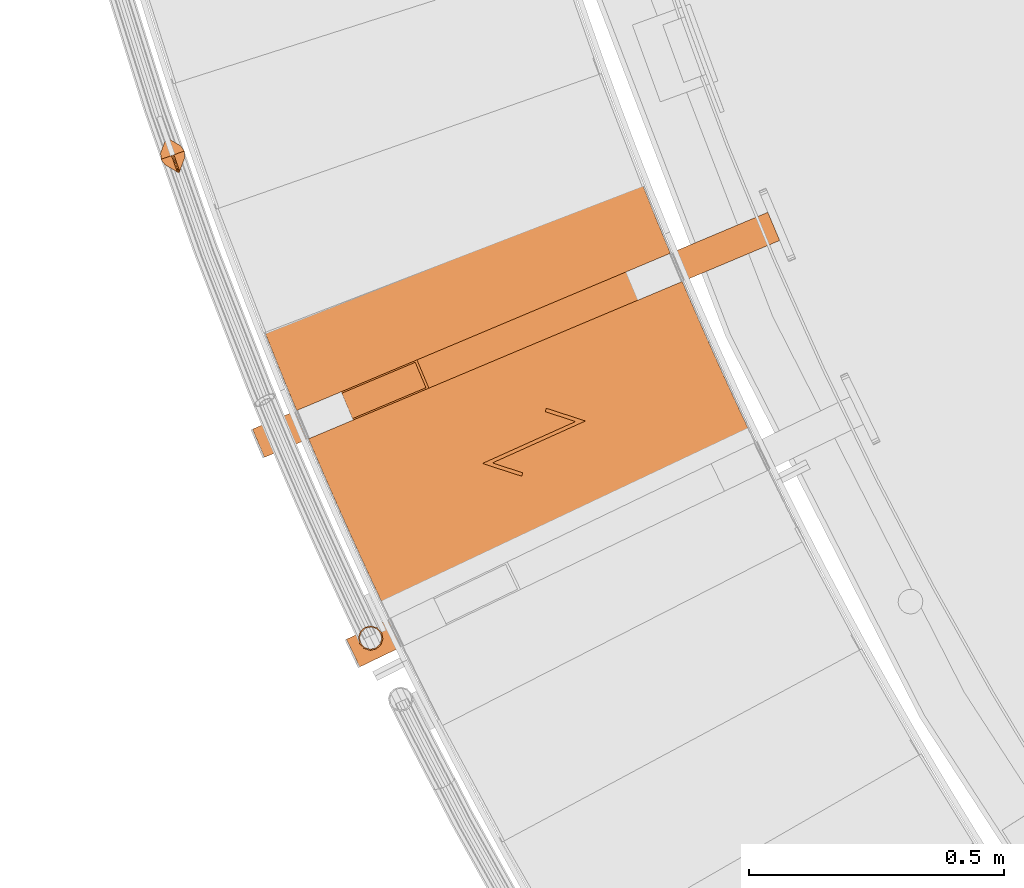
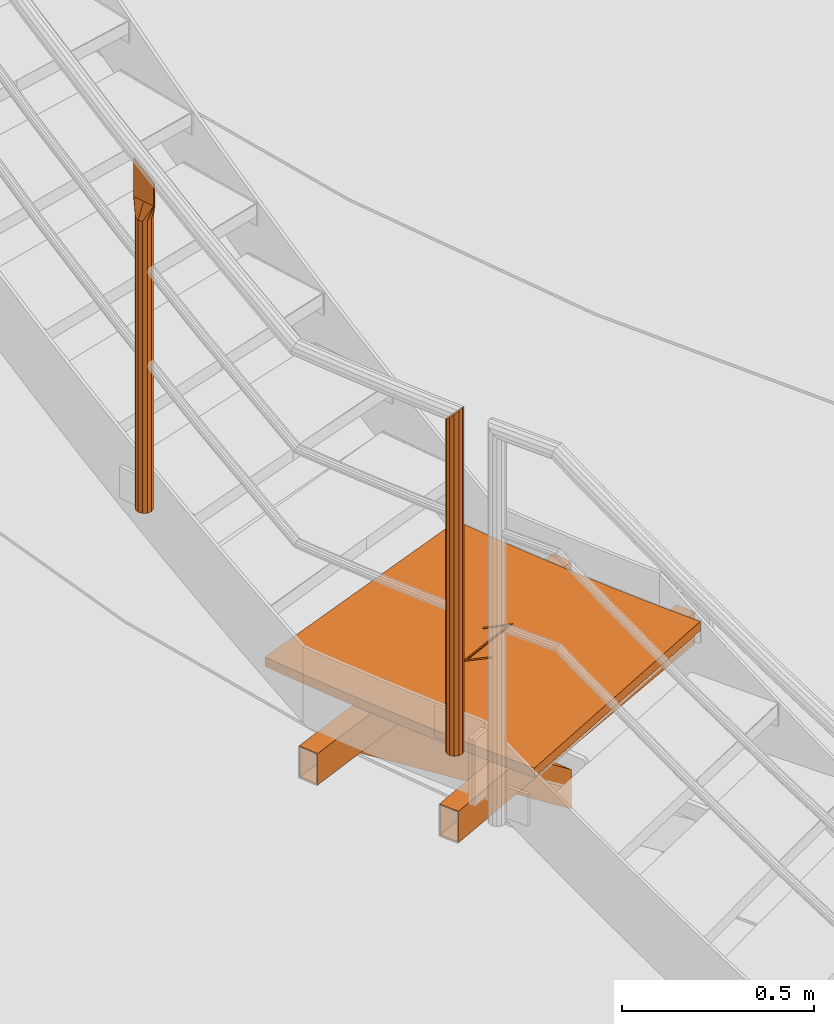
# One storey, part 9 of 126: 6 proxies.
"""IFC2X3 building model written with IfcOpenShell, lengths in millimetres."""

from ifc_helpers import new_model, si_unit, origin, origin_with_axes, place, context, project, spatial, faceted_brep, material, element, save


model = new_model("IFC2X3")

# Units and contexts
context_of_model_1 = context(None, 3, precision=0.1, world=origin())
context_of_model_2 = context(None, 3, precision=0.1, world=origin())
ifc_project = project(units=[si_unit("LENGTHUNIT", "METRE", prefix="MILLI"), si_unit("AREAUNIT", "SQUARE_METRE", prefix="CENTI"), si_unit("VOLUMEUNIT", "CUBIC_METRE", prefix="CENTI"), si_unit("MASSUNIT", "GRAM", prefix="KILO")], contexts=[context_of_model_1, context_of_model_2])

# Site, building, storey
site_placement = place(None, origin_with_axes())
site = spatial("IfcSite", under=ifc_project, at=site_placement, CompositionType="ELEMENT")
building_placement = place(site_placement, origin_with_axes())
building = spatial("IfcBuilding", under=site, at=building_placement, CompositionType="ELEMENT")
storey_placement = place(building_placement, origin_with_axes())
storey = spatial("IfcBuildingStorey", under=building, at=storey_placement, CompositionType="ELEMENT")

# Proxies
ifc_material_1 = material(Name="S235JRG2")
proxy_1_placement = place(storey_placement, origin_with_axes())
element("IfcBuildingElementProxy", 1, at=proxy_1_placement, inside=storey, material=ifc_material_1, Name="BLECH", context=context_of_model_2, shape_type="Brep", body=[
    faceted_brep([(155.165, 3996.6729, 2741.25), (151.2316, 4004.3761, 2741.25), (143.3947, 4019.7983, 2741.25), (135.5881, 4035.236, 2741.25), (127.8119, 4050.6888, 2741.25), (120.066, 4066.1569, 2741.25), (112.3505, 4081.6401, 2741.25), (104.6655, 4097.1383, 2741.25), (97.0107, 4112.6519, 2741.25), (89.3866, 4128.1801, 2741.25), (81.7929, 4143.7234, 2741.25), (74.2298, 4159.2816, 2741.25), (66.6972, 4174.8544, 2741.25), (59.1951, 4190.4423, 2741.25), (51.7237, 4206.0447, 2741.25), (44.2829, 4221.6618, 2741.25), (36.8728, 4237.2934, 2741.25), (29.4933, 4252.9395, 2741.25), (22.1445, 4268.6003, 2741.25), (14.8266, 4284.2752, 2741.25), (7.5393, 4299.9648, 2741.25), (0.2829, 4315.6684, 2741.25), (-6.9426, 4331.3863, 2741.25), (-14.1373, 4347.1182, 2741.25), (-21.3012, 4362.8643, 2741.25), (-28.4339, 4378.6242, 2741.25), (-35.536, 4394.3986, 2741.25), (-42.6068, 4410.1863, 2741.25), (-49.6468, 4425.9882, 2741.25), (-56.6557, 4441.8038, 2741.25), (-63.6336, 4457.6331, 2741.25), (-70.5804, 4473.4761, 2741.25), (-77.4961, 4489.3328, 2741.25), (-84.3806, 4505.2029, 2741.25), (-91.2341, 4521.0866, 2741.25), (-98.0562, 4536.9836, 2741.25), (-104.8472, 4552.8939, 2741.25), (-111.6071, 4568.8179, 2741.25), (-118.3355, 4584.7548, 2741.25), (-125.0327, 4600.7049, 2741.25), (-131.6987, 4616.6683, 2741.25), (-138.3331, 4632.6446, 2741.25), (-144.9362, 4648.6336, 2741.25), (-151.5081, 4664.636, 2741.25), (-158.0483, 4680.6508, 2741.25), (-164.5572, 4696.6788, 2741.25), (-171.0348, 4712.7197, 2741.25), (-177.4807, 4728.7729, 2741.25), (-183.895, 4744.8386, 2741.25), (-190.2779, 4760.9171, 2741.25), (-196.6291, 4777.008, 2741.25), (-199.7892, 4785.0601, 2741.25), (541.1115, 5070.6124, 2741.25), (543.9734, 5063.3328, 2741.25), (549.7253, 5048.7851, 2741.25), (555.5058, 5034.2483, 2741.25), (561.3144, 5019.7232, 2741.25), (567.1516, 5005.2089, 2741.25), (573.0167, 4990.7068, 2741.25), (578.9105, 4976.2155, 2741.25), (584.8324, 4961.7359, 2741.25), (590.7825, 4947.268, 2741.25), (596.7607, 4932.8118, 2741.25), (602.7673, 4918.3669, 2741.25), (608.8019, 4903.9342, 2741.25), (614.8647, 4889.5131, 2741.25), (620.9557, 4875.1038, 2741.25), (627.0746, 4860.7066, 2741.25), (633.2218, 4846.3212, 2741.25), (639.3969, 4831.9479, 2741.25), (645.6, 4817.5867, 2741.25), (651.8313, 4803.2373, 2741.25), (658.0904, 4788.9004, 2741.25), (664.3775, 4774.5757, 2741.25), (670.6926, 4760.2631, 2741.25), (677.0355, 4745.9632, 2741.25), (683.4063, 4731.6753, 2741.25), (689.805, 4717.4001, 2741.25), (696.2314, 4703.1375, 2741.25), (702.6857, 4688.8874, 2741.25), (709.1678, 4674.65, 2741.25), (715.6776, 4660.4251, 2741.25), (722.2153, 4646.2128, 2741.25), (728.7805, 4632.0135, 2741.25), (735.3736, 4617.8268, 2741.25), (741.9942, 4603.6532, 2741.25), (748.6425, 4589.4925, 2741.25), (755.3183, 4575.3449, 2741.25), (762.0219, 4561.2099, 2741.25), (768.753, 4547.0883, 2741.25), (775.5114, 4532.9802, 2741.25), (782.2974, 4518.8851, 2741.25), (789.111, 4504.803, 2741.25), (795.952, 4490.7344, 2741.25), (802.8204, 4476.6792, 2741.25), (809.7162, 4462.6375, 2741.25), (816.6396, 4448.6088, 2741.25), (823.5902, 4434.5939, 2741.25), (830.5679, 4420.593, 2741.25), (837.5733, 4406.6051, 2741.25), (844.6056, 4392.6314, 2741.25), (851.6653, 4378.6713, 2741.25), (858.7522, 4364.725, 2741.25), (862.3093, 4357.7585, 2741.25), (155.165, 3996.6729, 2771.25), (862.3093, 4357.7585, 2771.25), (858.7522, 4364.725, 2771.25), (851.6653, 4378.6713, 2771.25), (844.6056, 4392.6314, 2771.25), (837.5733, 4406.6051, 2771.25), (830.5679, 4420.593, 2771.25), (823.5902, 4434.5939, 2771.25), (816.6396, 4448.6088, 2771.25), (809.7162, 4462.6375, 2771.25), (802.8204, 4476.6792, 2771.25), (795.952, 4490.7344, 2771.25), (789.111, 4504.803, 2771.25), (782.2974, 4518.8851, 2771.25), (775.5114, 4532.9802, 2771.25), (768.753, 4547.0883, 2771.25), (762.0219, 4561.2099, 2771.25), (755.3183, 4575.3449, 2771.25), (748.6425, 4589.4925, 2771.25), (741.9942, 4603.6532, 2771.25), (735.3736, 4617.8268, 2771.25), (728.7805, 4632.0135, 2771.25), (722.2153, 4646.2128, 2771.25), (715.6776, 4660.4251, 2771.25), (709.1678, 4674.65, 2771.25), (702.6857, 4688.8874, 2771.25), (696.2314, 4703.1375, 2771.25), (689.805, 4717.4001, 2771.25), (683.4063, 4731.6753, 2771.25), (677.0355, 4745.9632, 2771.25), (670.6926, 4760.2631, 2771.25), (664.3775, 4774.5757, 2771.25), (658.0904, 4788.9004, 2771.25), (651.8313, 4803.2373, 2771.25), (645.6, 4817.5867, 2771.25), (639.3969, 4831.9479, 2771.25), (633.2218, 4846.3212, 2771.25), (627.0746, 4860.7066, 2771.25), (620.9557, 4875.1038, 2771.25), (614.8647, 4889.5131, 2771.25), (608.8019, 4903.9342, 2771.25), (602.7673, 4918.3669, 2771.25), (596.7607, 4932.8118, 2771.25), (590.7825, 4947.268, 2771.25), (584.8324, 4961.7359, 2771.25), (578.9105, 4976.2155, 2771.25), (573.0167, 4990.7068, 2771.25), (567.1516, 5005.2089, 2771.25), (561.3144, 5019.7232, 2771.25), (555.5058, 5034.2483, 2771.25), (549.7253, 5048.7851, 2771.25), (543.9734, 5063.3328, 2771.25), (541.1115, 5070.6124, 2771.25), (-199.7892, 4785.0601, 2771.25), (-196.6291, 4777.008, 2771.25), (-190.2779, 4760.9171, 2771.25), (-183.895, 4744.8386, 2771.25), (-177.4807, 4728.7729, 2771.25), (-171.0348, 4712.7197, 2771.25), (-164.5572, 4696.6788, 2771.25), (-158.0483, 4680.6508, 2771.25), (-151.5081, 4664.636, 2771.25), (-144.9362, 4648.6336, 2771.25), (-138.3331, 4632.6446, 2771.25), (-131.6987, 4616.6683, 2771.25), (-125.0327, 4600.7049, 2771.25), (-118.3355, 4584.7548, 2771.25), (-111.6071, 4568.8179, 2771.25), (-104.8472, 4552.8939, 2771.25), (-98.0562, 4536.9836, 2771.25), (-91.2341, 4521.0866, 2771.25), (-84.3806, 4505.2029, 2771.25), (-77.4961, 4489.3328, 2771.25), (-70.5804, 4473.4761, 2771.25), (-63.6336, 4457.6331, 2771.25), (-56.6557, 4441.8038, 2771.25), (-49.6468, 4425.9882, 2771.25), (-42.6068, 4410.1863, 2771.25), (-35.536, 4394.3986, 2771.25), (-28.4339, 4378.6242, 2771.25), (-21.3012, 4362.8643, 2771.25), (-14.1373, 4347.1182, 2771.25), (-6.9426, 4331.3863, 2771.25), (0.2829, 4315.6684, 2771.25), (7.5393, 4299.9648, 2771.25), (14.8266, 4284.2752, 2771.25), (22.1445, 4268.6003, 2771.25), (29.4933, 4252.9395, 2771.25), (36.8728, 4237.2934, 2771.25), (44.2829, 4221.6618, 2771.25), (51.7237, 4206.0447, 2771.25), (59.1951, 4190.4423, 2771.25), (66.6972, 4174.8544, 2771.25), (74.2298, 4159.2816, 2771.25), (81.7929, 4143.7234, 2771.25), (89.3866, 4128.1801, 2771.25), (97.0107, 4112.6519, 2771.25), (104.6655, 4097.1383, 2771.25), (112.3505, 4081.6401, 2771.25), (120.066, 4066.1569, 2771.25), (127.8119, 4050.6888, 2771.25), (135.5881, 4035.236, 2771.25), (143.3947, 4019.7983, 2771.25), (151.2316, 4004.3761, 2771.25), (356.1906, 4611.4076, 2771.25), (358.3479, 4618.0669, 2771.25), (435.1958, 4593.1716, 2771.25), (252.8512, 4511.0107, 2771.25), (312.4436, 4491.7054, 2771.25), (310.2863, 4485.0461, 2771.25), (233.4383, 4509.9414, 2771.25), (415.783, 4592.1023, 2771.25), (356.1906, 4611.4076, 2766.25), (358.3479, 4618.0669, 2766.25), (415.783, 4592.1023, 2766.25), (435.1958, 4593.1716, 2766.25), (233.4383, 4509.9414, 2766.25), (252.8512, 4511.0107, 2766.25), (310.2863, 4485.0461, 2766.25), (312.4436, 4491.7054, 2766.25)], [[[0, 1, 2, 3, 4, 5, 6, 7, 8, 9, 10, 11, 12, 13, 14, 15, 16, 17, 18, 19, 20, 21, 22, 23, 24, 25, 26, 27, 28, 29, 30, 31, 32, 33, 34, 35, 36, 37, 38, 39, 40, 41, 42, 43, 44, 45, 46, 47, 48, 49, 50, 51, 52, 53, 54, 55, 56, 57, 58, 59, 60, 61, 62, 63, 64, 65, 66, 67, 68, 69, 70, 71, 72, 73, 74, 75, 76, 77, 78, 79, 80, 81, 82, 83, 84, 85, 86, 87, 88, 89, 90, 91, 92, 93, 94, 95, 96, 97, 98, 99, 100, 101, 102, 103]], [[104, 105, 106, 107, 108, 109, 110, 111, 112, 113, 114, 115, 116, 117, 118, 119, 120, 121, 122, 123, 124, 125, 126, 127, 128, 129, 130, 131, 132, 133, 134, 135, 136, 137, 138, 139, 140, 141, 142, 143, 144, 145, 146, 147, 148, 149, 150, 151, 152, 153, 154, 155, 156, 157, 158, 159, 160, 161, 162, 163, 164, 165, 166, 167, 168, 169, 170, 171, 172, 173, 174, 175, 176, 177, 178, 179, 180, 181, 182, 183, 184, 185, 186, 187, 188, 189, 190, 191, 192, 193, 194, 195, 196, 197, 198, 199, 200, 201, 202, 203, 204, 205, 206, 207], [208, 209, 210, 211, 212, 213, 214, 215]], [[0, 104, 207, 1]], [[1, 207, 206, 2]], [[2, 206, 205, 3]], [[3, 205, 204, 4]], [[4, 204, 203, 5]], [[5, 203, 202, 6]], [[6, 202, 201, 7]], [[7, 201, 200, 8]], [[8, 200, 199, 9]], [[9, 199, 198, 10]], [[10, 198, 197, 11]], [[11, 197, 196, 12]], [[12, 196, 195, 13]], [[13, 195, 194, 14]], [[14, 194, 193, 15]], [[15, 193, 192, 16]], [[16, 192, 191, 17]], [[17, 191, 190, 18]], [[18, 190, 189, 19]], [[19, 189, 188, 20]], [[20, 188, 187, 21]], [[21, 187, 186, 22]], [[22, 186, 185, 23]], [[23, 185, 184, 24]], [[24, 184, 183, 25]], [[25, 183, 182, 26]], [[26, 182, 181, 27]], [[27, 181, 180, 28]], [[28, 180, 179, 29]], [[29, 179, 178, 30]], [[30, 178, 177, 31]], [[31, 177, 176, 32]], [[32, 176, 175, 33]], [[33, 175, 174, 34]], [[34, 174, 173, 35]], [[35, 173, 172, 36]], [[36, 172, 171, 37]], [[37, 171, 170, 38]], [[38, 170, 169, 39]], [[39, 169, 168, 40]], [[40, 168, 167, 41]], [[41, 167, 166, 42]], [[42, 166, 165, 43]], [[43, 165, 164, 44]], [[44, 164, 163, 45]], [[45, 163, 162, 46]], [[46, 162, 161, 47]], [[47, 161, 160, 48]], [[48, 160, 159, 49]], [[49, 159, 158, 50]], [[50, 158, 157, 51]], [[51, 157, 156, 52]], [[52, 156, 155, 53]], [[53, 155, 154, 54]], [[54, 154, 153, 55]], [[55, 153, 152, 56]], [[56, 152, 151, 57]], [[57, 151, 150, 58]], [[58, 150, 149, 59]], [[59, 149, 148, 60]], [[60, 148, 147, 61]], [[61, 147, 146, 62]], [[62, 146, 145, 63]], [[63, 145, 144, 64]], [[64, 144, 143, 65]], [[65, 143, 142, 66]], [[66, 142, 141, 67]], [[67, 141, 140, 68]], [[68, 140, 139, 69]], [[69, 139, 138, 70]], [[70, 138, 137, 71]], [[71, 137, 136, 72]], [[72, 136, 135, 73]], [[73, 135, 134, 74]], [[74, 134, 133, 75]], [[75, 133, 132, 76]], [[76, 132, 131, 77]], [[77, 131, 130, 78]], [[78, 130, 129, 79]], [[79, 129, 128, 80]], [[80, 128, 127, 81]], [[81, 127, 126, 82]], [[82, 126, 125, 83]], [[83, 125, 124, 84]], [[84, 124, 123, 85]], [[85, 123, 122, 86]], [[86, 122, 121, 87]], [[87, 121, 120, 88]], [[88, 120, 119, 89]], [[89, 119, 118, 90]], [[90, 118, 117, 91]], [[91, 117, 116, 92]], [[92, 116, 115, 93]], [[93, 115, 114, 94]], [[94, 114, 113, 95]], [[95, 113, 112, 96]], [[96, 112, 111, 97]], [[97, 111, 110, 98]], [[98, 110, 109, 99]], [[99, 109, 108, 100]], [[100, 108, 107, 101]], [[101, 107, 106, 102]], [[102, 106, 105, 103]], [[0, 103, 105, 104]], [[208, 216, 217, 209]], [[216, 218, 219, 217]], [[208, 215, 218, 216]], [[209, 217, 219, 210]], [[219, 218, 220, 221]], [[214, 220, 218, 215]], [[210, 219, 221, 211]], [[221, 220, 222, 223]], [[213, 222, 220, 214]], [[211, 221, 223, 212]], [[212, 223, 222, 213]]]),
])
proxy_2_placement = place(storey_placement, origin_with_axes())
element("IfcBuildingElementProxy", 2, at=proxy_2_placement, inside=storey, material=ifc_material_1, context=context_of_model_2, shape_type="Brep", body=[
    faceted_brep([(-6.7913, 4111.5783, 2521.25), (-6.7913, 4111.5783, 2621.25), (-32.8345, 4165.6316, 2621.25), (-32.8345, 4165.6316, 2521.25), (-8.0935, 4114.281, 2524.25), (-31.5323, 4162.9289, 2524.25), (-31.5323, 4162.9289, 2618.25), (-8.0935, 4114.281, 2618.25), (953.3427, 4640.7767, 2521.25), (979.3859, 4586.7235, 2521.25), (953.3427, 4640.7767, 2621.25), (979.3859, 4586.7235, 2621.25), (978.0837, 4589.4261, 2618.25), (978.0837, 4589.4261, 2524.25), (954.6449, 4638.074, 2618.25), (954.6449, 4638.074, 2524.25)], [[[0, 1, 2, 3], [4, 5, 6, 7]], [[0, 3, 8, 9]], [[2, 10, 8, 3]], [[1, 11, 10, 2]], [[0, 9, 11, 1]], [[4, 7, 12, 13]], [[6, 14, 12, 7]], [[5, 15, 14, 6]], [[4, 13, 15, 5]], [[9, 8, 10, 11], [12, 14, 15, 13]]]),
])
proxy_3_placement = place(storey_placement, origin_with_axes())
element("IfcBuildingElementProxy", 3, at=proxy_3_placement, inside=storey, material=ifc_material_1, context=context_of_model_2, shape_type="Brep", body=[
    faceted_brep([(-193.5107, 4521.9045, 2521.25), (-193.5107, 4521.9045, 2621.25), (-216.7858, 4577.2061, 2621.25), (-216.7858, 4577.2061, 2521.25), (-194.6745, 4524.6696, 2524.25), (-215.6221, 4574.441, 2524.25), (-215.6221, 4574.441, 2618.25), (-194.6745, 4524.6696, 2618.25), (792.1675, 5001.8492, 2521.25), (815.4425, 4946.5475, 2521.25), (792.1675, 5001.8492, 2621.25), (815.4425, 4946.5475, 2621.25), (814.2788, 4949.3126, 2618.25), (814.2788, 4949.3126, 2524.25), (793.3312, 4999.0841, 2618.25), (793.3312, 4999.0841, 2524.25)], [[[0, 1, 2, 3], [4, 5, 6, 7]], [[0, 3, 8, 9]], [[2, 10, 8, 3]], [[1, 11, 10, 2]], [[0, 9, 11, 1]], [[4, 7, 12, 13]], [[6, 14, 12, 7]], [[5, 15, 14, 6]], [[4, 13, 15, 5]], [[9, 8, 10, 11], [12, 14, 15, 13]]]),
])
proxy_4_placement = place(storey_placement, origin_with_axes())
element("IfcBuildingElementProxy", 4, at=proxy_4_placement, inside=storey, material=ifc_material_1, context=context_of_model_2, shape_type="Brep", body=[
    faceted_brep([(-24.5917, 4592.9983, 2521.25), (-47.8667, 4648.2999, 2521.25), (792.1675, 5001.8492, 1834.459), (815.4426, 4946.5475, 1834.459), (105.2856, 4712.7579, 2521.25), (792.1675, 5001.8492, 1959.6725), (128.5607, 4657.4563, 2521.25), (815.4426, 4946.5475, 1959.6725), (-21.1609, 4597.6971, 2521.25), (122.8024, 4658.2876, 2521.25), (814.2788, 4949.3126, 1955.9161), (814.2788, 4949.3126, 1838.2154), (101.8548, 4708.0591, 2521.25), (793.3312, 4999.0841, 1955.9161), (-42.1084, 4647.4686, 2521.25), (793.3312, 4999.0841, 1838.2154)], [[[0, 1, 2, 3]], [[1, 4, 5, 2]], [[4, 6, 7, 5]], [[0, 3, 7, 6]], [[8, 9, 10, 11]], [[9, 12, 13, 10]], [[12, 14, 15, 13]], [[8, 11, 15, 14]], [[1, 0, 6, 4], [8, 14, 12, 9]], [[3, 2, 5, 7], [10, 13, 15, 11]]]),
])
proxy_5_placement = place(storey_placement, origin_with_axes())
element("IfcBuildingElementProxy", 5, at=proxy_5_placement, inside=storey, material=ifc_material_1, Name="HANDLAUF", context=context_of_model_2, shape_type="Brep", body=[
    faceted_brep([(3.5192, 4189.5257, 3822.95), (15.7447, 4192.1354, 3826.1855), (15.7447, 4192.1354, 2771.25), (3.5192, 4189.5257, 2771.25), (27.6372, 4188.2828, 3835.025), (27.6372, 4188.2828, 2771.25), (36.0101, 4179.0001, 3847.1), (36.0101, 4179.0001, 2771.25), (38.6198, 4166.7746, 3859.175), (38.6198, 4166.7746, 2771.25), (34.7672, 4154.8821, 3868.0145), (34.7672, 4154.8821, 2771.25), (25.4845, 4146.5092, 3871.25), (25.4845, 4146.5092, 2771.25), (13.259, 4143.8994, 3868.0145), (13.259, 4143.8994, 2771.25), (1.3665, 4147.7521, 3859.175), (1.3665, 4147.7521, 2771.25), (-7.0064, 4157.0348, 3847.1), (-7.0064, 4157.0348, 2771.25), (-9.6162, 4169.2603, 3835.025), (-9.6162, 4169.2603, 2771.25), (-5.7635, 4181.1528, 3826.1855), (-5.7635, 4181.1528, 2771.25), (4.6561, 4187.2991, 3825.45), (-3.6657, 4179.793, 3828.3506), (-3.6657, 4179.793, 2771.25), (4.6561, 4187.2991, 2771.25), (-7.1195, 4169.1316, 3836.275), (-7.1195, 4169.1316, 2771.25), (-4.7799, 4158.1717, 3847.1), (-4.7799, 4158.1717, 2771.25), (2.7263, 4149.8499, 3857.925), (2.7263, 4149.8499, 2771.25), (13.3876, 4146.3961, 3865.8495), (13.3876, 4146.3961, 2771.25), (24.3476, 4148.7357, 3868.75), (24.3476, 4148.7357, 2771.25), (32.6693, 4156.2419, 3865.8495), (32.6693, 4156.2419, 2771.25), (36.1232, 4166.9032, 3857.925), (36.1232, 4166.9032, 2771.25), (33.7835, 4177.8632, 3847.1), (33.7835, 4177.8632, 2771.25), (26.2774, 4186.1849, 3836.275), (26.2774, 4186.1849, 2771.25), (15.616, 4189.6387, 3828.3506), (15.616, 4189.6387, 2771.25)], [[[0, 1, 2, 3]], [[1, 4, 5, 2]], [[4, 6, 7, 5]], [[6, 8, 9, 7]], [[8, 10, 11, 9]], [[10, 12, 13, 11]], [[12, 14, 15, 13]], [[14, 16, 17, 15]], [[16, 18, 19, 17]], [[18, 20, 21, 19]], [[20, 22, 23, 21]], [[0, 3, 23, 22]], [[24, 25, 26, 27]], [[25, 28, 29, 26]], [[28, 30, 31, 29]], [[30, 32, 33, 31]], [[32, 34, 35, 33]], [[34, 36, 37, 35]], [[36, 38, 39, 37]], [[38, 40, 41, 39]], [[40, 42, 43, 41]], [[42, 44, 45, 43]], [[44, 46, 47, 45]], [[24, 27, 47, 46]], [[18, 16, 14, 12, 10, 8, 6, 4, 1, 0, 22, 20], [24, 46, 44, 42, 40, 38, 36, 34, 32, 30, 28, 25]], [[19, 21, 23, 3, 2, 5, 7, 9, 11, 13, 15, 17], [26, 29, 31, 33, 35, 37, 39, 41, 43, 45, 47, 27]]]),
])
ifc_material_2 = material(Name="1.4462")
proxy_6_placement = place(storey_placement, origin_with_axes())
element("IfcBuildingElementProxy", 6, at=proxy_6_placement, inside=storey, material=ifc_material_2, Name="Pfosten", context=context_of_model_2, shape_type="Brep", body=[
    faceted_brep([(-365.021, 5090.7974, 4033.9549), (-377.4851, 5089.8374, 4033.9549), (-377.4851, 5089.8374, 3105.0986), (-365.021, 5090.7974, 3105.0976), (-388.7593, 5095.238, 4033.9549), (-388.7593, 5095.238, 3105.1012), (-395.8227, 5105.5521, 4033.9549), (-395.8227, 5105.5521, 3105.1049), (-396.7827, 5118.0162, 4033.9549), (-396.7827, 5118.0162, 3105.1085), (-391.3821, 5129.2904, 4033.9549), (-391.3821, 5129.2904, 3105.1111), (-381.0679, 5136.3538, 4033.9549), (-381.0679, 5136.3538, 3105.1121), (-368.6039, 5137.3138, 4033.9549), (-368.6039, 5137.3138, 3105.1111), (-357.3297, 5131.9132, 4033.9549), (-357.3297, 5131.9132, 3105.1085), (-350.2663, 5121.599, 4033.9549), (-350.2663, 5121.599, 3105.1049), (-349.3062, 5109.135, 4033.9549), (-349.3062, 5109.135, 3105.1012), (-354.7069, 5097.8608, 4033.9549), (-354.7069, 5097.8608, 3105.0986), (-358.9565, 5130.0149, 4033.9549), (-369.0636, 5134.8565, 4033.9549), (-369.0636, 5134.8565, 3105.1105), (-358.9565, 5130.0149, 3105.1081), (-380.2373, 5133.9958, 4033.9549), (-380.2373, 5133.9958, 3105.1113), (-389.4838, 5127.6636, 4033.9549), (-389.4838, 5127.6636, 3105.1105), (-394.3253, 5117.5565, 4033.9549), (-394.3253, 5117.5565, 3105.1081), (-393.4647, 5106.3827, 4033.9549), (-393.4647, 5106.3827, 3105.1049), (-387.1325, 5097.1363, 4033.9549), (-387.1325, 5097.1363, 3105.1016), (-377.0254, 5092.2947, 4033.9549), (-377.0254, 5092.2947, 3105.0992), (-365.8516, 5093.1554, 4033.9549), (-365.8516, 5093.1554, 3105.0984), (-356.6052, 5099.4876, 4033.9549), (-356.6052, 5099.4876, 3105.0992), (-351.7636, 5109.5947, 4033.9549), (-351.7636, 5109.5947, 3105.1016), (-352.6243, 5120.7685, 4033.9549), (-352.6243, 5120.7685, 3105.1049), (-360.9154, 5079.1416, 4082.2549), (-362.826, 5079.2449, 4082.2549), (-364.1039, 5080.669, 4082.2549), (-375.4025, 5112.745, 4082.2549), (-386.701, 5144.821, 4082.2549), (-386.5977, 5146.7316, 4082.2549), (-385.1736, 5148.0096, 4082.2549), (-383.263, 5147.9063, 4082.2549), (-381.985, 5146.4822, 4082.2549), (-370.6865, 5114.4062, 4082.2549), (-359.388, 5082.3302, 4082.2549), (-359.4913, 5080.4196, 4082.2549), (-384.1544, 5145.718, 4082.2549), (-384.2566, 5145.832, 4082.2549), (-384.4095, 5145.8402, 4082.2549), (-384.5234, 5145.738, 4082.2549), (-384.5317, 5145.5851, 4082.2549), (-373.2331, 5113.5091, 4082.2549), (-361.9346, 5081.4331, 4082.2549), (-361.8323, 5081.3192, 4082.2549), (-361.6795, 5081.311, 4082.2549), (-361.5656, 5081.4132, 4082.2549), (-361.5573, 5081.566, 4082.2549), (-372.8558, 5113.642, 4082.2549), (-360.9154, 5079.1416, 4153.3782), (-362.826, 5079.2449, 4153.8941), (-364.1039, 5080.669, 4155.1397), (-375.4025, 5112.745, 4179.1022), (-386.701, 5144.821, 4203.0648), (-386.5977, 5146.7316, 4204.3104), (-385.1736, 5148.0096, 4204.8263), (-383.263, 5147.9063, 4204.3104), (-381.985, 5146.4822, 4203.0648), (-370.6865, 5114.4062, 4179.1022), (-359.388, 5082.3302, 4155.1397), (-359.4913, 5080.4196, 4153.8941), (-384.1544, 5145.718, 4203.0648), (-384.2566, 5145.832, 4203.1644), (-384.4095, 5145.8402, 4203.2057), (-384.5234, 5145.738, 4203.1644), (-384.5317, 5145.5851, 4203.0648), (-373.2331, 5113.5091, 4179.1022), (-361.9346, 5081.4331, 4155.1397), (-361.8323, 5081.3192, 4155.0401), (-361.6795, 5081.311, 4154.9988), (-361.5656, 5081.4132, 4155.0401), (-361.5573, 5081.566, 4155.1397), (-372.8558, 5113.642, 4179.1022)], [[[0, 1, 2, 3]], [[1, 4, 5, 2]], [[4, 6, 7, 5]], [[6, 8, 9, 7]], [[8, 10, 11, 9]], [[10, 12, 13, 11]], [[12, 14, 15, 13]], [[14, 16, 17, 15]], [[16, 18, 19, 17]], [[18, 20, 21, 19]], [[20, 22, 23, 21]], [[0, 3, 23, 22]], [[24, 25, 26, 27]], [[25, 28, 29, 26]], [[28, 30, 31, 29]], [[30, 32, 33, 31]], [[32, 34, 35, 33]], [[34, 36, 37, 35]], [[36, 38, 39, 37]], [[38, 40, 41, 39]], [[40, 42, 43, 41]], [[42, 44, 45, 43]], [[44, 46, 47, 45]], [[24, 27, 47, 46]], [[0, 48, 49, 1]], [[1, 49, 50, 4]], [[4, 50, 51, 6]], [[6, 51, 52, 8]], [[8, 52, 53, 10]], [[10, 53, 54, 12]], [[12, 54, 55, 14]], [[14, 55, 56, 16]], [[16, 56, 57, 18]], [[18, 57, 58, 20]], [[20, 58, 59, 22]], [[22, 59, 48, 0]], [[24, 60, 61, 25]], [[25, 61, 62, 28]], [[28, 62, 63, 30]], [[30, 63, 64, 32]], [[32, 64, 65, 34]], [[34, 65, 66, 36]], [[36, 66, 67, 38]], [[38, 67, 68, 40]], [[40, 68, 69, 42]], [[42, 69, 70, 44]], [[44, 70, 71, 46]], [[46, 71, 60, 24]], [[48, 72, 73, 49]], [[49, 73, 74, 50]], [[50, 74, 75, 51]], [[51, 75, 76, 52]], [[52, 76, 77, 53]], [[53, 77, 78, 54]], [[54, 78, 79, 55]], [[55, 79, 80, 56]], [[56, 80, 81, 57]], [[57, 81, 82, 58]], [[58, 82, 83, 59]], [[48, 59, 83, 72]], [[60, 84, 85, 61]], [[61, 85, 86, 62]], [[62, 86, 87, 63]], [[63, 87, 88, 64]], [[64, 88, 89, 65]], [[65, 89, 90, 66]], [[66, 90, 91, 67]], [[67, 91, 92, 68]], [[68, 92, 93, 69]], [[69, 93, 94, 70]], [[70, 94, 95, 71]], [[60, 71, 95, 84]], [[7, 9, 11, 13, 15, 17, 19, 21, 23, 3, 2, 5], [26, 29, 31, 33, 35, 37, 39, 41, 43, 45, 47, 27]], [[74, 73, 72, 83, 82, 81, 80, 79, 78, 77, 76, 75], [84, 95, 94, 93, 92, 91, 90, 89, 88, 87, 86, 85]]]),
])

save(model, "model.ifc")
